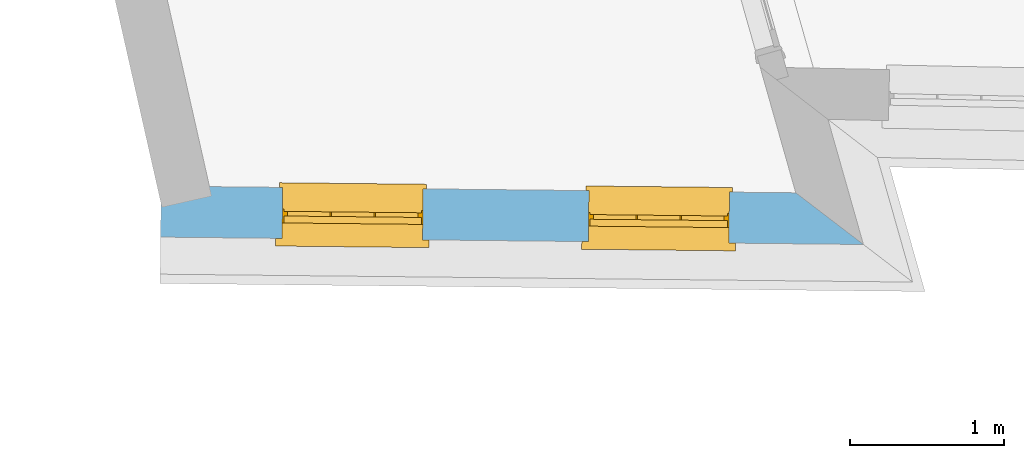
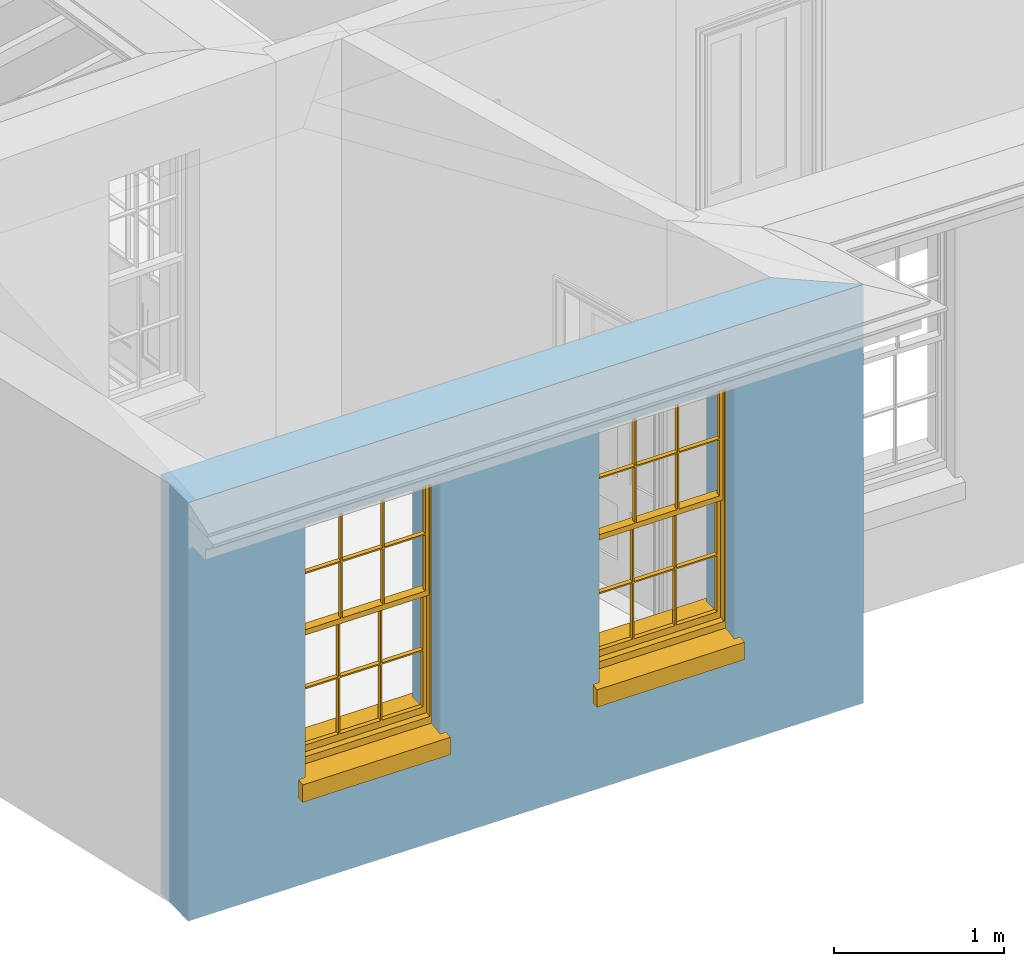
# One storey, part 2 of 11: 2 windows, 2 openings, plus 1 element that does not belong to this part.
"""IFC2X3 building model written with IfcOpenShell, lengths in metres."""

from ifc_helpers import new_model, si_unit, frame, origin, place, context, subcontext, project, spatial, polyline, outline, extrude, faceted_brep, material, layer, layer_set, layer_usage, element, fill, save


model = new_model("IFC2X3")

# Units and contexts
model_context = context("Model", 3, world=origin())
body_context = subcontext(model_context, "Body", "Model", "MODEL_VIEW")
ifc_project = project(units=[si_unit("PLANEANGLEUNIT", "RADIAN"), si_unit("MASSUNIT", "GRAM", prefix="KILO"), si_unit("FORCEUNIT", "NEWTON", prefix="KILO"), si_unit("LENGTHUNIT", "METRE")], contexts=[model_context])

# Site, building, storey
site_placement = place(None, origin())
site = spatial("IfcSite", under=ifc_project, at=site_placement, CompositionType="ELEMENT")
building_placement = place(None, origin())
building = spatial("IfcBuilding", under=site, at=building_placement, Name="Building plot-10", CompositionType="ELEMENT")
storey_placement = place(None, frame((0.0, 0.0, 4.6)))
storey = spatial("IfcBuildingStorey", under=building, at=storey_placement, Name="Floor 1", CompositionType="ELEMENT", Elevation=4.6)

# Wall, openings, windows
ifc_material = material(Name="Masonry")
ifc_layer = layer(ifc_material, 0.33, ventilated=False)
ifc_layer_set = layer_set([ifc_layer], Name="My Wall")
ifc_layer_usage = layer_usage(ifc_layer_set, "AXIS2", "NEGATIVE", 0.08)
wall_placement = place(storey_placement, origin())
wall = element("IfcWallStandardCase", 1, at=wall_placement, inside=storey, material=ifc_layer_usage, Name="exterior", context=body_context, shape_type="SweptSolid", body=[
    extrude(outline(polyline([(42.2033835145621, 16.5829484354506), (42.1999090329559, 16.2529667269006), (46.749222478465, 16.2050655691155), (46.3113508516478, 16.5396943502031), (42.2033835145621, 16.5829484354506)])), origin(), (0.0, 0.0, 1.0), 3.0),
])
opening_1_placement = place(storey_placement, frame((0.0, 0.0, 0.75)))
opening_1 = element("IfcOpeningElement", 2, at=opening_1_placement, cuts=wall, Name="Opening", ObjectType="Opening", context=body_context, shape_type="SweptSolid", body=[
    extrude(outline(polyline([(42.9861639433829, 16.2446880006764), (43.8961135033238, 16.2351068544289), (43.89958798493, 16.5650885629789), (42.9896384249891, 16.5746697092264), (42.9861639433829, 16.2446880006764)])), origin(), (0.0, 0.0, 1.0), 1.82),
])
opening_2_placement = place(storey_placement, frame((0.0, 0.0, 0.75)))
opening_2 = element("IfcOpeningElement", 3, at=opening_2_placement, cuts=wall, Name="Opening", ObjectType="Opening", context=body_context, shape_type="SweptSolid", body=[
    extrude(outline(polyline([(44.968651038496, 16.2238137680504), (45.8786005984369, 16.2142326218029), (45.8820750800431, 16.5442143303529), (44.9721255201022, 16.5537954766004), (44.968651038496, 16.2238137680504)])), origin(), (0.0, 0.0, 1.0), 1.82),
])
window_1_placement = place(storey_placement, frame((42.9887961264179, 16.4946741435173, 0.75), z_axis=(0.0, 0.0, 1.0), x_axis=(0.90994955994087, -0.00958114624751261, 0.0)))
window_1 = element("IfcWindow", 4, at=window_1_placement, inside=storey, Name="bedroom outside window", OverallHeight=1.82, OverallWidth=0.91, context=body_context, shape_type="Brep", held_by="IfcProductRepresentation", body=[
    faceted_brep([(0.033125, -0.105, 0.975209), (0.01, -0.105, 0.975209), (0.033125, -0.105, 1.376042), (0.876875, -0.105, 0.975209), (0.876875, -0.105, 1.376042), (0.9, -0.105, 0.975209), (0.876875, -0.105, 1.386042), (0.876875, -0.105, 1.786875), (0.9, -0.105, 1.81), (0.033125, -0.105, 1.786875), (0.033125, -0.105, 1.386042), (0.01, -0.105, 1.81), (0.876875, -0.135, 1.376042), (0.876875, -0.135, 0.975209), (0.9, -0.135, 0.937083), (0.033125, -0.135, 1.786875), (0.01, -0.135, 1.81), (0.033125, -0.135, 1.386042), (0.01, -0.135, 0.937083), (0.033125, -0.135, 0.975209), (0.033125, -0.135, 1.376042), (0.876875, -0.135, 1.786875), (0.876875, -0.135, 1.386042), (0.9, -0.135, 1.81), (0.033125, -0.105, 0.937083), (0.01, -0.105, 0.937083), (0.033125, -0.105, 0.53625), (0.876875, -0.105, 0.937083), (0.876875, -0.105, 0.53625), (0.9, -0.105, 0.937083), (0.876875, -0.105, 0.52625), (0.876875, -0.105, 0.125417), (0.9, -0.105, 0.077167), (0.033125, -0.105, 0.125417), (0.033125, -0.105, 0.52625), (0.01, -0.105, 0.077167), (-0.0425, -0.25, 0.01), (-0.0425, -0.3, 0.001667), (0.0, -0.25, 0.01), (0.9525, -0.25, 0.01), (0.91, -0.25, 0.01), (0.9525, -0.3, 0.001667), (-0.02, 0.08, 0.077167), (0.0, 0.08, 0.077167), (-0.02, 0.11, 0.077167), (0.0, -0.06, 0.077167), (0.01, -0.06, 0.077167), (0.91, -0.06, 0.077167), (0.91, 0.08, 0.077167), (0.9, -0.06, 0.077167), (0.93, 0.08, 0.077167), (0.93, 0.11, 0.077167), (0.01, -0.075, 0.975209), (0.9, -0.075, 0.975209), (0.876875, -0.075, 0.125417), (0.876875, -0.075, 0.52625), (0.9, -0.075, 0.077167), (0.876875, -0.075, 0.53625), (0.876875, -0.075, 0.937083), (0.033125, -0.075, 0.125417), (0.01, -0.075, 0.077167), (0.033125, -0.075, 0.52625), (0.033125, -0.075, 0.937083), (0.033125, -0.075, 0.53625), (-0.02, 0.08, 0.052167), (-0.02, 0.11, 0.052167), (0.93, 0.11, 0.052167), (0.93, 0.08, 0.052167), (0.91, 0.08, 0.052167), (0.0, 0.08, 0.052167), (0.91, -0.15, 0.026667), (0.0, -0.15, 0.026667), (-0.0425, -0.3, -0.123333), (0.9525, -0.3, -0.123333), (-0.0425, -0.25, -0.123333), (0.9525, -0.25, -0.123333), (0.01, -0.06, 1.81), (0.9, -0.06, 1.81), (0.0, -0.06, 1.82), (0.91, -0.06, 1.82), (0.01, -0.15, 0.077167), (0.9, -0.15, 0.077167), (0.592292, -0.105, 0.125417), (0.592292, -0.075, 0.125417), (0.317708, -0.075, 0.125417), (0.317708, -0.105, 0.125417), (0.592292, -0.105, 0.53625), (0.317708, -0.105, 0.53625), (0.317708, -0.105, 0.52625), (0.592292, -0.105, 0.52625), (0.592292, -0.075, 0.53625), (0.317708, -0.075, 0.53625), (0.592292, -0.135, 1.386042), (0.592292, -0.105, 1.386042), (0.317708, -0.105, 1.386042), (0.317708, -0.135, 1.386042), (0.317708, -0.135, 1.376042), (0.592292, -0.135, 1.376042), (0.317708, -0.105, 1.376042), (0.592292, -0.105, 1.376042), (0.602292, -0.135, 1.376042), (0.592292, -0.135, 0.975209), (0.602292, -0.135, 0.975209), (0.602292, -0.105, 0.975209), (0.592292, -0.105, 0.975209), (0.602292, -0.105, 1.376042), (0.602292, -0.075, 0.53625), (0.602292, -0.105, 0.53625), (0.317708, -0.075, 0.52625), (0.307708, -0.075, 0.125417), (0.307708, -0.075, 0.52625), (0.602292, -0.075, 0.52625), (0.602292, -0.075, 0.125417), (0.592292, -0.075, 0.52625), (0.307708, -0.075, 0.53625), (0.317708, -0.075, 0.937083), (0.307708, -0.075, 0.937083), (0.602292, -0.075, 0.937083), (0.592292, -0.075, 0.937083), (0.307708, -0.105, 0.52625), (0.307708, -0.105, 0.125417), (0.307708, -0.105, 0.53625), (0.307708, -0.105, 0.937083), (0.592292, -0.105, 0.937083), (0.317708, -0.105, 0.937083), (0.602292, -0.105, 0.937083), (0.602292, -0.105, 0.52625), (0.602292, -0.105, 0.125417), (0.307708, -0.135, 1.386042), (0.307708, -0.135, 1.376042), (0.307708, -0.135, 0.975209), (0.317708, -0.135, 0.975209), (0.317708, -0.135, 1.786875), (0.307708, -0.135, 1.786875), (0.602292, -0.135, 1.786875), (0.592292, -0.135, 1.786875), (0.602292, -0.135, 1.386042), (0.602292, -0.105, 1.386042), (0.307708, -0.105, 1.386042), (0.307708, -0.105, 1.786875), (0.317708, -0.105, 1.786875), (0.592292, -0.105, 1.786875), (0.602292, -0.105, 1.786875), (0.307708, -0.105, 1.376042), (0.317708, -0.105, 0.975209), (0.307708, -0.105, 0.975209), (0.91, -0.15, 1.82), (0.9, -0.15, 1.81), (0.01, -0.15, 1.81), (0.0, -0.15, 1.82), (0.91, -0.25, 0.0), (0.0, -0.25, 0.0), (0.91, 0.08, 0.0), (0.0, 0.08, 0.0)], [[[0, 1, 2]], [[3, 4, 5]], [[6, 7, 8]], [[9, 10, 11]], [[12, 13, 14]], [[15, 16, 17]], [[18, 19, 20]], [[21, 22, 23]], [[24, 25, 26]], [[27, 28, 29]], [[30, 31, 32]], [[33, 34, 35]], [[14, 27, 29]], [[25, 24, 18]], [[36, 37, 38]], [[39, 40, 41]], [[42, 43, 44]], [[45, 46, 43]], [[47, 48, 49]], [[50, 51, 48]], [[1, 0, 52]], [[5, 53, 3]], [[54, 55, 56]], [[57, 58, 53]], [[59, 60, 61]], [[62, 63, 52]], [[48, 43, 46, 49]], [[51, 44, 43, 48]], [[64, 42, 44, 65]], [[65, 44, 51, 66]], [[66, 51, 50, 67]], [[65, 66, 68, 69]], [[60, 56, 49, 46]], [[70, 71, 38, 40]], [[37, 41, 40, 38]], [[37, 72, 73, 41]], [[74, 75, 73, 72]], [[8, 11, 76, 77]], [[76, 78, 79, 77]], [[32, 35, 80, 81]], [[81, 80, 71, 70]], [[82, 83, 84, 85]], [[86, 87, 88, 89]], [[86, 90, 91, 87]], [[92, 93, 94, 95]], [[92, 95, 96, 97]], [[96, 98, 99, 97]], [[100, 97, 101, 102]], [[103, 104, 99, 105]], [[97, 99, 104, 101]], [[102, 103, 105, 100]], [[28, 57, 106, 107]], [[108, 84, 109, 110]], [[111, 112, 83, 113]], [[114, 110, 61, 63]], [[90, 113, 108, 91]], [[115, 91, 114, 116]], [[117, 106, 90, 118]], [[111, 106, 57, 55]], [[119, 110, 109, 120]], [[34, 61, 110, 119]], [[89, 113, 83, 82]], [[88, 108, 113, 89]], [[85, 84, 108, 88]], [[121, 114, 63, 26]], [[122, 116, 114, 121]], [[123, 118, 90, 86]], [[87, 91, 115, 124]], [[107, 106, 117, 125]], [[126, 111, 55, 30]], [[127, 112, 111, 126]], [[126, 30, 28, 107]], [[88, 119, 120, 85]], [[126, 89, 82, 127]], [[125, 123, 86, 107]], [[121, 26, 34, 119]], [[124, 122, 121, 87]], [[128, 17, 20, 129]], [[96, 129, 130, 131]], [[132, 133, 128, 95]], [[134, 135, 92, 136]], [[100, 12, 22, 136]], [[137, 6, 4, 105]], [[94, 138, 139, 140]], [[137, 93, 141, 142]], [[99, 98, 94, 93]], [[143, 2, 10, 138]], [[144, 145, 143, 98]], [[129, 143, 145, 130]], [[20, 2, 143, 129]], [[131, 144, 98, 96]], [[128, 138, 10, 17]], [[133, 139, 138, 128]], [[135, 141, 93, 92]], [[95, 94, 140, 132]], [[22, 6, 137, 136]], [[136, 137, 142, 134]], [[100, 105, 4, 12]], [[107, 86, 89, 126]], [[106, 111, 113, 90]], [[91, 108, 110, 114]], [[87, 121, 119, 88]], [[97, 100, 136, 92]], [[129, 96, 95, 128]], [[98, 143, 138, 94]], [[105, 99, 93, 137]], [[131, 101, 104, 144]], [[124, 115, 118, 123]], [[132, 140, 141, 135]], [[120, 109, 59, 33]], [[15, 9, 139, 133]], [[134, 142, 7, 21]], [[31, 54, 112, 127]], [[36, 74, 72, 37]], [[39, 41, 73, 75]], [[18, 14, 101, 131]], [[23, 16, 132, 135]], [[83, 56, 60, 84]], [[52, 53, 118, 115]], [[53, 52, 144, 104]], [[11, 8, 141, 140]], [[14, 18, 124, 123]], [[2, 1, 11, 10]], [[8, 5, 4, 6]], [[57, 53, 56, 55]], [[60, 52, 63, 61]], [[26, 25, 35, 34]], [[32, 29, 28, 30]], [[14, 23, 22, 12]], [[18, 20, 17, 16]], [[19, 0, 2, 20]], [[17, 10, 9, 15]], [[12, 4, 3, 13]], [[21, 7, 6, 22]], [[27, 58, 57, 28]], [[30, 55, 54, 31]], [[33, 59, 61, 34]], [[26, 63, 62, 24]], [[5, 8, 77, 53]], [[76, 11, 1, 52]], [[46, 45, 78, 76]], [[49, 77, 79, 47]], [[70, 146, 147, 81]], [[71, 80, 148, 149]], [[19, 130, 145, 0]], [[102, 13, 3, 103]], [[116, 122, 24, 62]], [[29, 32, 81, 14]], [[80, 35, 25, 18]], [[60, 46, 76, 52]], [[77, 49, 56, 53]], [[23, 14, 81, 147]], [[16, 148, 80, 18]], [[35, 85, 120]], [[120, 33, 35]], [[127, 82, 32]], [[32, 31, 127]], [[32, 82, 85, 35]], [[102, 101, 14]], [[14, 13, 102]], [[18, 131, 130]], [[130, 19, 18]], [[134, 21, 23]], [[23, 135, 134]], [[16, 15, 133]], [[133, 132, 16]], [[11, 140, 139]], [[139, 9, 11]], [[142, 141, 8]], [[8, 7, 142]], [[23, 147, 148, 16]], [[146, 149, 148, 147]], [[52, 115, 116]], [[116, 62, 52]], [[118, 53, 117]], [[58, 117, 53]], [[27, 125, 117, 58]], [[56, 83, 112]], [[112, 54, 56]], [[109, 84, 60]], [[60, 59, 109]], [[125, 27, 14]], [[14, 123, 125]], [[122, 124, 18]], [[18, 24, 122]], [[145, 144, 52]], [[52, 0, 145]], [[103, 3, 53]], [[53, 104, 103]], [[79, 78, 149, 146]], [[78, 45, 71, 149]], [[146, 70, 47, 79]], [[150, 75, 74, 151]], [[68, 66, 67]], [[48, 68, 67, 50]], [[69, 64, 65]], [[42, 64, 69, 43]], [[69, 68, 152, 153]], [[70, 68, 48, 47]], [[150, 152, 68, 70]], [[43, 69, 71, 45]], [[69, 153, 151, 71]], [[152, 150, 151, 153]], [[38, 151, 74, 36]], [[71, 151, 38]], [[39, 75, 150, 40]], [[40, 150, 70]]]),
])
fill(opening_1, window_1)
window_2_placement = place(storey_placement, frame((44.971283221531, 16.4737999108913, 0.75), z_axis=(0.0, 0.0, 1.0), x_axis=(0.90994955994087, -0.00958114624751261, 0.0)))
window_2 = element("IfcWindow", 5, at=window_2_placement, inside=storey, Name="bedroom outside window", OverallHeight=1.82, OverallWidth=0.91, context=body_context, shape_type="Brep", held_by="IfcProductRepresentation", body=[
    faceted_brep([(0.033125, -0.105, 0.975209), (0.01, -0.105, 0.975209), (0.033125, -0.105, 1.376042), (0.876875, -0.105, 0.975209), (0.876875, -0.105, 1.376042), (0.9, -0.105, 0.975209), (0.876875, -0.105, 1.386042), (0.876875, -0.105, 1.786875), (0.9, -0.105, 1.81), (0.033125, -0.105, 1.786875), (0.033125, -0.105, 1.386042), (0.01, -0.105, 1.81), (0.876875, -0.135, 1.376042), (0.876875, -0.135, 0.975209), (0.9, -0.135, 0.937083), (0.033125, -0.135, 1.786875), (0.01, -0.135, 1.81), (0.033125, -0.135, 1.386042), (0.01, -0.135, 0.937083), (0.033125, -0.135, 0.975209), (0.033125, -0.135, 1.376042), (0.876875, -0.135, 1.786875), (0.876875, -0.135, 1.386042), (0.9, -0.135, 1.81), (0.033125, -0.105, 0.937083), (0.01, -0.105, 0.937083), (0.033125, -0.105, 0.53625), (0.876875, -0.105, 0.937083), (0.876875, -0.105, 0.53625), (0.9, -0.105, 0.937083), (0.876875, -0.105, 0.52625), (0.876875, -0.105, 0.125417), (0.9, -0.105, 0.077167), (0.033125, -0.105, 0.125417), (0.033125, -0.105, 0.52625), (0.01, -0.105, 0.077167), (-0.0425, -0.25, 0.01), (-0.0425, -0.3, 0.001667), (0.0, -0.25, 0.01), (0.9525, -0.25, 0.01), (0.91, -0.25, 0.01), (0.9525, -0.3, 0.001667), (-0.02, 0.08, 0.077167), (0.0, 0.08, 0.077167), (-0.02, 0.11, 0.077167), (0.0, -0.06, 0.077167), (0.01, -0.06, 0.077167), (0.91, -0.06, 0.077167), (0.91, 0.08, 0.077167), (0.9, -0.06, 0.077167), (0.93, 0.08, 0.077167), (0.93, 0.11, 0.077167), (0.01, -0.075, 0.975209), (0.9, -0.075, 0.975209), (0.876875, -0.075, 0.125417), (0.876875, -0.075, 0.52625), (0.9, -0.075, 0.077167), (0.876875, -0.075, 0.53625), (0.876875, -0.075, 0.937083), (0.033125, -0.075, 0.125417), (0.01, -0.075, 0.077167), (0.033125, -0.075, 0.52625), (0.033125, -0.075, 0.937083), (0.033125, -0.075, 0.53625), (-0.02, 0.08, 0.052167), (-0.02, 0.11, 0.052167), (0.93, 0.11, 0.052167), (0.93, 0.08, 0.052167), (0.91, 0.08, 0.052167), (0.0, 0.08, 0.052167), (0.91, -0.15, 0.026667), (0.0, -0.15, 0.026667), (-0.0425, -0.3, -0.123333), (0.9525, -0.3, -0.123333), (-0.0425, -0.25, -0.123333), (0.9525, -0.25, -0.123333), (0.01, -0.06, 1.81), (0.9, -0.06, 1.81), (0.0, -0.06, 1.82), (0.91, -0.06, 1.82), (0.01, -0.15, 0.077167), (0.9, -0.15, 0.077167), (0.592292, -0.105, 0.125417), (0.592292, -0.075, 0.125417), (0.317708, -0.075, 0.125417), (0.317708, -0.105, 0.125417), (0.592292, -0.105, 0.53625), (0.317708, -0.105, 0.53625), (0.317708, -0.105, 0.52625), (0.592292, -0.105, 0.52625), (0.592292, -0.075, 0.53625), (0.317708, -0.075, 0.53625), (0.592292, -0.135, 1.386042), (0.592292, -0.105, 1.386042), (0.317708, -0.105, 1.386042), (0.317708, -0.135, 1.386042), (0.317708, -0.135, 1.376042), (0.592292, -0.135, 1.376042), (0.317708, -0.105, 1.376042), (0.592292, -0.105, 1.376042), (0.602292, -0.135, 1.376042), (0.592292, -0.135, 0.975209), (0.602292, -0.135, 0.975209), (0.602292, -0.105, 0.975209), (0.592292, -0.105, 0.975209), (0.602292, -0.105, 1.376042), (0.602292, -0.075, 0.53625), (0.602292, -0.105, 0.53625), (0.317708, -0.075, 0.52625), (0.307708, -0.075, 0.125417), (0.307708, -0.075, 0.52625), (0.602292, -0.075, 0.52625), (0.602292, -0.075, 0.125417), (0.592292, -0.075, 0.52625), (0.307708, -0.075, 0.53625), (0.317708, -0.075, 0.937083), (0.307708, -0.075, 0.937083), (0.602292, -0.075, 0.937083), (0.592292, -0.075, 0.937083), (0.307708, -0.105, 0.52625), (0.307708, -0.105, 0.125417), (0.307708, -0.105, 0.53625), (0.307708, -0.105, 0.937083), (0.592292, -0.105, 0.937083), (0.317708, -0.105, 0.937083), (0.602292, -0.105, 0.937083), (0.602292, -0.105, 0.52625), (0.602292, -0.105, 0.125417), (0.307708, -0.135, 1.386042), (0.307708, -0.135, 1.376042), (0.307708, -0.135, 0.975209), (0.317708, -0.135, 0.975209), (0.317708, -0.135, 1.786875), (0.307708, -0.135, 1.786875), (0.602292, -0.135, 1.786875), (0.592292, -0.135, 1.786875), (0.602292, -0.135, 1.386042), (0.602292, -0.105, 1.386042), (0.307708, -0.105, 1.386042), (0.307708, -0.105, 1.786875), (0.317708, -0.105, 1.786875), (0.592292, -0.105, 1.786875), (0.602292, -0.105, 1.786875), (0.307708, -0.105, 1.376042), (0.317708, -0.105, 0.975209), (0.307708, -0.105, 0.975209), (0.91, -0.15, 1.82), (0.9, -0.15, 1.81), (0.01, -0.15, 1.81), (0.0, -0.15, 1.82), (0.91, -0.25, 0.0), (0.0, -0.25, 0.0), (0.91, 0.08, 0.0), (0.0, 0.08, 0.0)], [[[0, 1, 2]], [[3, 4, 5]], [[6, 7, 8]], [[9, 10, 11]], [[12, 13, 14]], [[15, 16, 17]], [[18, 19, 20]], [[21, 22, 23]], [[24, 25, 26]], [[27, 28, 29]], [[30, 31, 32]], [[33, 34, 35]], [[14, 27, 29]], [[25, 24, 18]], [[36, 37, 38]], [[39, 40, 41]], [[42, 43, 44]], [[45, 46, 43]], [[47, 48, 49]], [[50, 51, 48]], [[1, 0, 52]], [[5, 53, 3]], [[54, 55, 56]], [[57, 58, 53]], [[59, 60, 61]], [[62, 63, 52]], [[48, 43, 46, 49]], [[51, 44, 43, 48]], [[64, 42, 44, 65]], [[65, 44, 51, 66]], [[66, 51, 50, 67]], [[65, 66, 68, 69]], [[60, 56, 49, 46]], [[70, 71, 38, 40]], [[37, 41, 40, 38]], [[37, 72, 73, 41]], [[74, 75, 73, 72]], [[8, 11, 76, 77]], [[76, 78, 79, 77]], [[32, 35, 80, 81]], [[81, 80, 71, 70]], [[82, 83, 84, 85]], [[86, 87, 88, 89]], [[86, 90, 91, 87]], [[92, 93, 94, 95]], [[92, 95, 96, 97]], [[96, 98, 99, 97]], [[100, 97, 101, 102]], [[103, 104, 99, 105]], [[97, 99, 104, 101]], [[102, 103, 105, 100]], [[28, 57, 106, 107]], [[108, 84, 109, 110]], [[111, 112, 83, 113]], [[114, 110, 61, 63]], [[90, 113, 108, 91]], [[115, 91, 114, 116]], [[117, 106, 90, 118]], [[111, 106, 57, 55]], [[119, 110, 109, 120]], [[34, 61, 110, 119]], [[89, 113, 83, 82]], [[88, 108, 113, 89]], [[85, 84, 108, 88]], [[121, 114, 63, 26]], [[122, 116, 114, 121]], [[123, 118, 90, 86]], [[87, 91, 115, 124]], [[107, 106, 117, 125]], [[126, 111, 55, 30]], [[127, 112, 111, 126]], [[126, 30, 28, 107]], [[88, 119, 120, 85]], [[126, 89, 82, 127]], [[125, 123, 86, 107]], [[121, 26, 34, 119]], [[124, 122, 121, 87]], [[128, 17, 20, 129]], [[96, 129, 130, 131]], [[132, 133, 128, 95]], [[134, 135, 92, 136]], [[100, 12, 22, 136]], [[137, 6, 4, 105]], [[94, 138, 139, 140]], [[137, 93, 141, 142]], [[99, 98, 94, 93]], [[143, 2, 10, 138]], [[144, 145, 143, 98]], [[129, 143, 145, 130]], [[20, 2, 143, 129]], [[131, 144, 98, 96]], [[128, 138, 10, 17]], [[133, 139, 138, 128]], [[135, 141, 93, 92]], [[95, 94, 140, 132]], [[22, 6, 137, 136]], [[136, 137, 142, 134]], [[100, 105, 4, 12]], [[107, 86, 89, 126]], [[106, 111, 113, 90]], [[91, 108, 110, 114]], [[87, 121, 119, 88]], [[97, 100, 136, 92]], [[129, 96, 95, 128]], [[98, 143, 138, 94]], [[105, 99, 93, 137]], [[131, 101, 104, 144]], [[124, 115, 118, 123]], [[132, 140, 141, 135]], [[120, 109, 59, 33]], [[15, 9, 139, 133]], [[134, 142, 7, 21]], [[31, 54, 112, 127]], [[36, 74, 72, 37]], [[39, 41, 73, 75]], [[18, 14, 101, 131]], [[23, 16, 132, 135]], [[83, 56, 60, 84]], [[52, 53, 118, 115]], [[53, 52, 144, 104]], [[11, 8, 141, 140]], [[14, 18, 124, 123]], [[2, 1, 11, 10]], [[8, 5, 4, 6]], [[57, 53, 56, 55]], [[60, 52, 63, 61]], [[26, 25, 35, 34]], [[32, 29, 28, 30]], [[14, 23, 22, 12]], [[18, 20, 17, 16]], [[19, 0, 2, 20]], [[17, 10, 9, 15]], [[12, 4, 3, 13]], [[21, 7, 6, 22]], [[27, 58, 57, 28]], [[30, 55, 54, 31]], [[33, 59, 61, 34]], [[26, 63, 62, 24]], [[5, 8, 77, 53]], [[76, 11, 1, 52]], [[46, 45, 78, 76]], [[49, 77, 79, 47]], [[70, 146, 147, 81]], [[71, 80, 148, 149]], [[19, 130, 145, 0]], [[102, 13, 3, 103]], [[116, 122, 24, 62]], [[29, 32, 81, 14]], [[80, 35, 25, 18]], [[60, 46, 76, 52]], [[77, 49, 56, 53]], [[23, 14, 81, 147]], [[16, 148, 80, 18]], [[35, 85, 120]], [[120, 33, 35]], [[127, 82, 32]], [[32, 31, 127]], [[32, 82, 85, 35]], [[102, 101, 14]], [[14, 13, 102]], [[18, 131, 130]], [[130, 19, 18]], [[134, 21, 23]], [[23, 135, 134]], [[16, 15, 133]], [[133, 132, 16]], [[11, 140, 139]], [[139, 9, 11]], [[142, 141, 8]], [[8, 7, 142]], [[23, 147, 148, 16]], [[146, 149, 148, 147]], [[52, 115, 116]], [[116, 62, 52]], [[118, 53, 117]], [[58, 117, 53]], [[27, 125, 117, 58]], [[56, 83, 112]], [[112, 54, 56]], [[109, 84, 60]], [[60, 59, 109]], [[125, 27, 14]], [[14, 123, 125]], [[122, 124, 18]], [[18, 24, 122]], [[145, 144, 52]], [[52, 0, 145]], [[103, 3, 53]], [[53, 104, 103]], [[79, 78, 149, 146]], [[78, 45, 71, 149]], [[146, 70, 47, 79]], [[150, 75, 74, 151]], [[68, 66, 67]], [[48, 68, 67, 50]], [[69, 64, 65]], [[42, 64, 69, 43]], [[69, 68, 152, 153]], [[70, 68, 48, 47]], [[150, 152, 68, 70]], [[43, 69, 71, 45]], [[69, 153, 151, 71]], [[152, 150, 151, 153]], [[38, 151, 74, 36]], [[71, 151, 38]], [[39, 75, 150, 40]], [[40, 150, 70]]]),
])
fill(opening_2, window_2)

save(model, "model.ifc")
